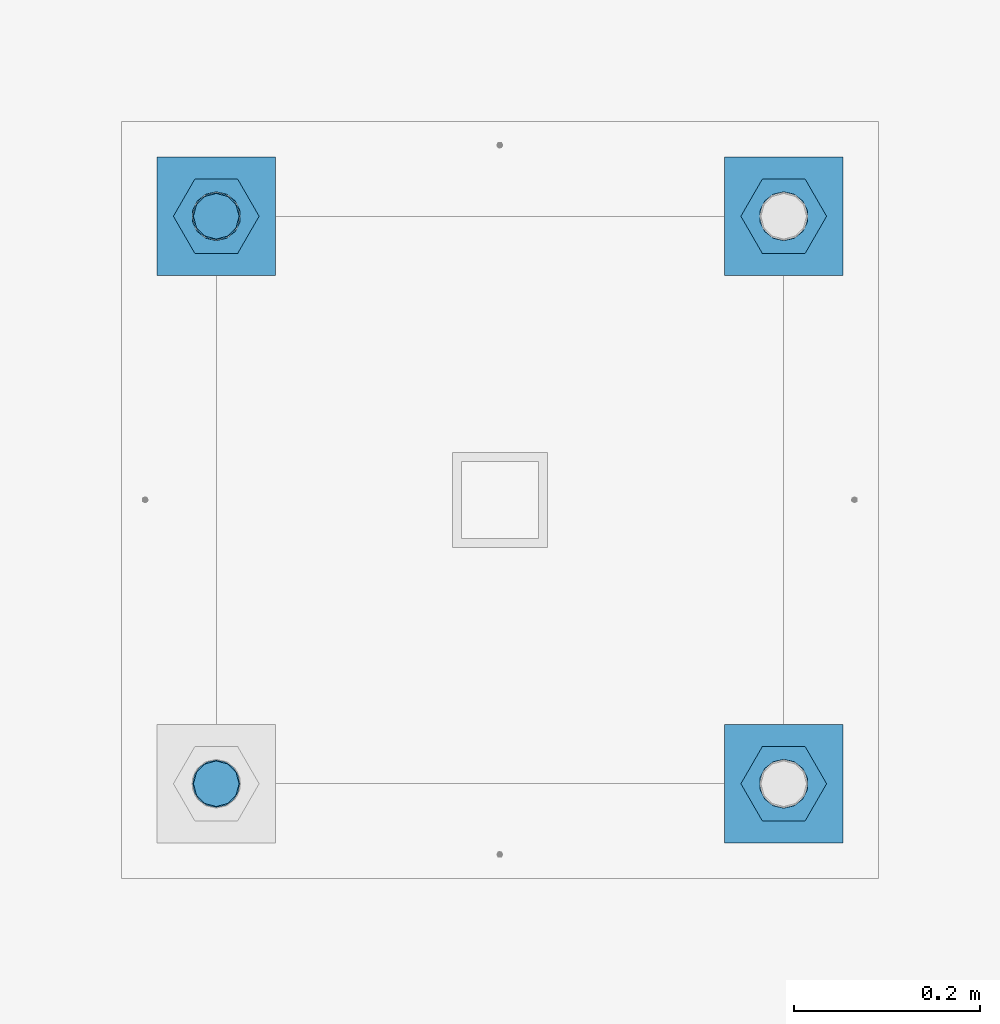
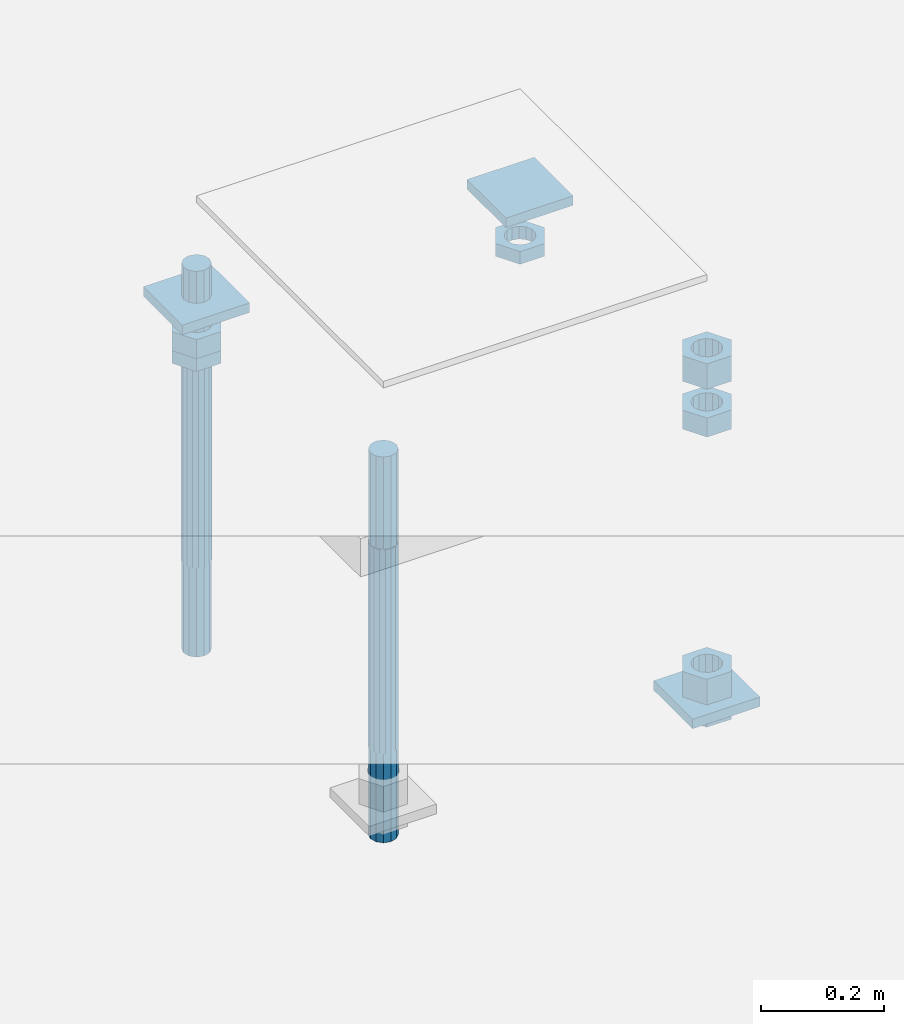
# One storey, part 2746 of 3843: 12 beams, 1 element without a shape of its own.
"""IFC2X3 building model written with IfcOpenShell, lengths in millimetres."""

from ifc_helpers import new_model, si_unit, frame, origin_with_axes, place, context, subcontext, project, spatial, faceted_brep, material, type_object, element, aggregate, save


model = new_model("IFC2X3")

# Units and contexts
model_context = context("Model", 3, precision=1e-05, world=origin_with_axes())
body_context = subcontext(model_context, "Body", "Model", "MODEL_VIEW")
ifc_project = project(units=[si_unit("LENGTHUNIT", "METRE", prefix="MILLI"), si_unit("AREAUNIT", "SQUARE_METRE"), si_unit("VOLUMEUNIT", "CUBIC_METRE"), si_unit("MASSUNIT", "GRAM", prefix="KILO"), si_unit("TIMEUNIT", "SECOND"), si_unit("PLANEANGLEUNIT", "RADIAN"), si_unit("SOLIDANGLEUNIT", "STERADIAN"), si_unit("THERMODYNAMICTEMPERATUREUNIT", "DEGREE_CELSIUS"), si_unit("LUMINOUSINTENSITYUNIT", "LUMEN")], contexts=[model_context])

# Site, building, storey
site_placement = place(None, origin_with_axes())
site = spatial("IfcSite", under=ifc_project, at=site_placement, CompositionType="ELEMENT")
building_placement = place(site_placement, origin_with_axes())
building = spatial("IfcBuilding", under=site, at=building_placement, Name="Undefined", CompositionType="ELEMENT")
storey_placement = place(building_placement, origin_with_axes())
storey = spatial("IfcBuildingStorey", under=building, at=storey_placement, Name="Undefined", CompositionType="ELEMENT", Elevation=0.0)

# Assembly, beams
assembly_placement = place(storey_placement, origin_with_axes())
assembly = element("IfcElementAssembly", 1, at=assembly_placement, inside=storey, Name="TEMPLATE", AssemblyPlace="NOTDEFINED", PredefinedType="RIGID_FRAME")
ifc_material_1 = material(Name="STEEL/A36")
beam_type_1 = type_object("IfcBeamType", PredefinedType="NOTDEFINED")
beam_1_placement = place(assembly_placement, frame((115798.6, 42113.2000015259, 29873.575), z_axis=(1.0, 0.0, 0.0), x_axis=(0.0, 1.0, 0.0)))
beam_1 = element("IfcBeam", 2, at=beam_1_placement, type_object=beam_type_1, material=ifc_material_1, Name="WASHER_PLATE", context=body_context, shape_type="Brep", body=[
    faceted_brep([(0.0, 9.52500000000146, -63.5), (0.0, 9.52500000000146, 63.5), (127.0, 9.52500000000146, 63.5), (127.0, 9.52500000000146, -63.5), (0.0, -9.52500000000146, 63.5), (127.0, -9.52500000000146, 63.5), (0.0, -9.52500000000146, -63.5), (127.0, -9.52500000000146, -63.5)], [[[0, 1, 2, 3]], [[1, 4, 5, 2]], [[4, 6, 7, 5]], [[6, 0, 3, 7]], [[5, 7, 3, 2]], [[6, 4, 1, 0]]]),
])
beam_2_placement = place(assembly_placement, frame((116408.2, 42113.2000015259, 29873.575), z_axis=(1.0, 0.0, 0.0), x_axis=(0.0, 1.0, 0.0)))
beam_2 = element("IfcBeam", 3, at=beam_2_placement, type_object=beam_type_1, material=ifc_material_1, Name="WASHER_PLATE", context=body_context, shape_type="Brep", body=[
    faceted_brep([(0.0, 9.52500000000146, -63.5), (0.0, 9.52500000000146, 63.5), (127.0, 9.52500000000146, 63.5), (127.0, 9.52500000000146, -63.5), (0.0, -9.52500000000146, 63.5), (127.0, -9.52500000000146, 63.5), (0.0, -9.52500000000146, -63.5), (127.0, -9.52500000000146, -63.5)], [[[0, 1, 2, 3]], [[1, 4, 5, 2]], [[4, 6, 7, 5]], [[6, 0, 3, 7]], [[5, 7, 3, 2]], [[6, 4, 1, 0]]]),
])
beam_3_placement = place(assembly_placement, frame((116408.2, 41503.6000015259, 29244.925), z_axis=(1.0, 0.0, 0.0), x_axis=(0.0, 1.0, 0.0)))
beam_3 = element("IfcBeam", 4, at=beam_3_placement, type_object=beam_type_1, material=ifc_material_1, Name="WASHER_PLATE", context=body_context, shape_type="Brep", body=[
    faceted_brep([(0.0, 9.52500000000146, -63.5), (0.0, 9.52500000000146, 63.5), (127.0, 9.52500000000146, 63.5), (127.0, 9.52500000000146, -63.5), (0.0, -9.52500000000146, 63.5), (127.0, -9.52500000000146, 63.5), (0.0, -9.52500000000146, -63.5), (127.0, -9.52500000000146, -63.5)], [[[0, 1, 2, 3]], [[1, 4, 5, 2]], [[4, 6, 7, 5]], [[6, 0, 3, 7]], [[5, 7, 3, 2]], [[6, 4, 1, 0]]]),
])
beam_type_2 = type_object("IfcBeamType", Name="2_HALF_NUT", PredefinedType="NOTDEFINED")
beam_4_placement = place(assembly_placement, frame((115798.6, 42176.7000015259, 29787.85), z_axis=(0.0, 1.0, 0.0), x_axis=(0.0, 0.0, -1.0)))
beam_4 = element("IfcBeam", 5, at=beam_4_placement, type_object=beam_type_2, material=ifc_material_1, Name="NUT", ObjectType="2_HALF_NUT", context=body_context, shape_type="Brep", body=[
    faceted_brep([(0.0, -46.0369987487793, 0.0), (0.0, -23.0184993743896, -39.869213104248), (25.4000000000015, -23.0184993743896, -39.869213104248), (25.4000000000015, -46.0369987487793, 0.0), (0.0, 23.0184993743896, -39.869213104248), (25.4000000000015, 23.0184993743896, -39.869213104248), (0.0, 46.0369987487793, 0.0), (25.4000000000015, 46.0369987487793, 0.0), (0.0, 23.0184993743896, 39.869213104248), (25.4000000000015, 23.0184993743896, 39.869213104248), (0.0, -23.0184993743896, 39.869213104248), (25.4000000000015, -23.0184993743896, 39.869213104248), (0.0, 0.0, 26.1940002441406), (0.0, 11.3650617044477, 23.5999013092805), (25.4000000000015, 11.3650617044477, 23.5999013092805), (25.4000000000015, 0.0, 26.1940002441406), (0.0, 20.4791109456419, 16.3316083006721), (25.4000000000015, 20.4791109456419, 16.3316083006721), (0.0, 25.5370200498292, 5.82867859874386), (25.4000000000015, 25.5370200498292, 5.82867859874386), (0.0, 25.5370200498292, -5.82867859874386), (25.4000000000015, 25.5370200498292, -5.82867859874386), (0.0, 20.4791109456419, -16.3316083006721), (25.4000000000015, 20.4791109456419, -16.3316083006721), (0.0, 11.3650617044477, -23.5999013092805), (25.4000000000015, 11.3650617044477, -23.5999013092805), (0.0, 0.0, -26.1940002441406), (25.4000000000015, 0.0, -26.1940002441406), (0.0, -11.3650617044477, -23.5999013092805), (25.4000000000015, -11.3650617044477, -23.5999013092805), (0.0, -20.4791109456419, -16.3316083006721), (25.4000000000015, -20.4791109456419, -16.3316083006721), (0.0, -25.5370200498292, -5.82867859874386), (25.4000000000015, -25.5370200498292, -5.82867859874386), (0.0, -25.5370200498292, 5.82867859874386), (25.4000000000015, -25.5370200498292, 5.82867859874386), (0.0, -20.4791109456419, 16.3316083006721), (25.4000000000015, -20.4791109456419, 16.3316083006721), (0.0, -11.3650617044477, 23.5999013092805), (25.4000000000015, -11.3650617044477, 23.5999013092805)], [[[0, 1, 2, 3]], [[1, 4, 5, 2]], [[4, 6, 7, 5]], [[6, 8, 9, 7]], [[8, 10, 11, 9]], [[10, 0, 3, 11]], [[12, 13, 14, 15]], [[13, 16, 17, 14]], [[16, 18, 19, 17]], [[18, 20, 21, 19]], [[20, 22, 23, 21]], [[22, 24, 25, 23]], [[24, 26, 27, 25]], [[26, 28, 29, 27]], [[28, 30, 31, 29]], [[30, 32, 33, 31]], [[32, 34, 35, 33]], [[34, 36, 37, 35]], [[36, 38, 39, 37]], [[38, 12, 15, 39]], [[5, 7, 9, 11, 3, 2], [17, 19, 21, 23, 25, 27, 29, 31, 33, 35, 37, 39, 15, 14]], [[10, 8, 6, 4, 1, 0], [38, 36, 34, 32, 30, 28, 26, 24, 22, 20, 18, 16, 13, 12]]]),
])
beam_5_placement = place(assembly_placement, frame((116408.2, 42176.7000015259, 29787.85), z_axis=(0.0, 1.0, 0.0), x_axis=(0.0, 0.0, -1.0)))
beam_5 = element("IfcBeam", 6, at=beam_5_placement, type_object=beam_type_2, material=ifc_material_1, Name="NUT", ObjectType="2_HALF_NUT", context=body_context, shape_type="Brep", body=[
    faceted_brep([(0.0, -46.0369987487793, 0.0), (0.0, -23.0184993743896, -39.869213104248), (25.4000000000015, -23.0184993743896, -39.869213104248), (25.4000000000015, -46.0369987487793, 0.0), (0.0, 23.0184993743896, -39.869213104248), (25.4000000000015, 23.0184993743896, -39.869213104248), (0.0, 46.0369987487793, 0.0), (25.4000000000015, 46.0369987487793, 0.0), (0.0, 23.0184993743896, 39.869213104248), (25.4000000000015, 23.0184993743896, 39.869213104248), (0.0, -23.0184993743896, 39.869213104248), (25.4000000000015, -23.0184993743896, 39.869213104248), (0.0, 0.0, 26.1940002441406), (0.0, 11.3650617044477, 23.5999013092805), (25.4000000000015, 11.3650617044477, 23.5999013092805), (25.4000000000015, 0.0, 26.1940002441406), (0.0, 20.4791109456419, 16.3316083006721), (25.4000000000015, 20.4791109456419, 16.3316083006721), (0.0, 25.5370200498292, 5.82867859874386), (25.4000000000015, 25.5370200498292, 5.82867859874386), (0.0, 25.5370200498292, -5.82867859874386), (25.4000000000015, 25.5370200498292, -5.82867859874386), (0.0, 20.4791109456419, -16.3316083006721), (25.4000000000015, 20.4791109456419, -16.3316083006721), (0.0, 11.3650617044477, -23.5999013092805), (25.4000000000015, 11.3650617044477, -23.5999013092805), (0.0, 0.0, -26.1940002441406), (25.4000000000015, 0.0, -26.1940002441406), (0.0, -11.3650617044477, -23.5999013092805), (25.4000000000015, -11.3650617044477, -23.5999013092805), (0.0, -20.4791109456419, -16.3316083006721), (25.4000000000015, -20.4791109456419, -16.3316083006721), (0.0, -25.5370200498292, -5.82867859874386), (25.4000000000015, -25.5370200498292, -5.82867859874386), (0.0, -25.5370200498292, 5.82867859874386), (25.4000000000015, -25.5370200498292, 5.82867859874386), (0.0, -20.4791109456419, 16.3316083006721), (25.4000000000015, -20.4791109456419, 16.3316083006721), (0.0, -11.3650617044477, 23.5999013092805), (25.4000000000015, -11.3650617044477, 23.5999013092805)], [[[0, 1, 2, 3]], [[1, 4, 5, 2]], [[4, 6, 7, 5]], [[6, 8, 9, 7]], [[8, 10, 11, 9]], [[10, 0, 3, 11]], [[12, 13, 14, 15]], [[13, 16, 17, 14]], [[16, 18, 19, 17]], [[18, 20, 21, 19]], [[20, 22, 23, 21]], [[22, 24, 25, 23]], [[24, 26, 27, 25]], [[26, 28, 29, 27]], [[28, 30, 31, 29]], [[30, 32, 33, 31]], [[32, 34, 35, 33]], [[34, 36, 37, 35]], [[36, 38, 39, 37]], [[38, 12, 15, 39]], [[5, 7, 9, 11, 3, 2], [17, 19, 21, 23, 25, 27, 29, 31, 33, 35, 37, 39, 15, 14]], [[10, 8, 6, 4, 1, 0], [38, 36, 34, 32, 30, 28, 26, 24, 22, 20, 18, 16, 13, 12]]]),
])
beam_6_placement = place(assembly_placement, frame((116408.2, 41567.1000015259, 29235.4), z_axis=(0.0, 1.0, 0.0), x_axis=(0.0, 0.0, -1.0)))
beam_6 = element("IfcBeam", 7, at=beam_6_placement, type_object=beam_type_2, material=ifc_material_1, Name="NUT", ObjectType="2_HALF_NUT", context=body_context, shape_type="Brep", body=[
    faceted_brep([(0.0, -46.0369987487793, 0.0), (0.0, -23.0184993743896, -39.869213104248), (25.4000000000015, -23.0184993743896, -39.869213104248), (25.4000000000015, -46.0369987487793, 0.0), (0.0, 23.0184993743896, -39.869213104248), (25.4000000000015, 23.0184993743896, -39.869213104248), (0.0, 46.0369987487793, 0.0), (25.4000000000015, 46.0369987487793, 0.0), (0.0, 23.0184993743896, 39.869213104248), (25.4000000000015, 23.0184993743896, 39.869213104248), (0.0, -23.0184993743896, 39.869213104248), (25.4000000000015, -23.0184993743896, 39.869213104248), (0.0, 0.0, 26.1940002441406), (0.0, 11.3650617044477, 23.5999013092805), (25.4000000000015, 11.3650617044477, 23.5999013092805), (25.4000000000015, 0.0, 26.1940002441406), (0.0, 20.4791109456419, 16.3316083006721), (25.4000000000015, 20.4791109456419, 16.3316083006721), (0.0, 25.5370200498292, 5.82867859874386), (25.4000000000015, 25.5370200498292, 5.82867859874386), (0.0, 25.5370200498292, -5.82867859874386), (25.4000000000015, 25.5370200498292, -5.82867859874386), (0.0, 20.4791109456419, -16.3316083006721), (25.4000000000015, 20.4791109456419, -16.3316083006721), (0.0, 11.3650617044477, -23.5999013092805), (25.4000000000015, 11.3650617044477, -23.5999013092805), (0.0, 0.0, -26.1940002441406), (25.4000000000015, 0.0, -26.1940002441406), (0.0, -11.3650617044477, -23.5999013092805), (25.4000000000015, -11.3650617044477, -23.5999013092805), (0.0, -20.4791109456419, -16.3316083006721), (25.4000000000015, -20.4791109456419, -16.3316083006721), (0.0, -25.5370200498292, -5.82867859874386), (25.4000000000015, -25.5370200498292, -5.82867859874386), (0.0, -25.5370200498292, 5.82867859874386), (25.4000000000015, -25.5370200498292, 5.82867859874386), (0.0, -20.4791109456419, 16.3316083006721), (25.4000000000015, -20.4791109456419, 16.3316083006721), (0.0, -11.3650617044477, 23.5999013092805), (25.4000000000015, -11.3650617044477, 23.5999013092805)], [[[0, 1, 2, 3]], [[1, 4, 5, 2]], [[4, 6, 7, 5]], [[6, 8, 9, 7]], [[8, 10, 11, 9]], [[10, 0, 3, 11]], [[12, 13, 14, 15]], [[13, 16, 17, 14]], [[16, 18, 19, 17]], [[18, 20, 21, 19]], [[20, 22, 23, 21]], [[22, 24, 25, 23]], [[24, 26, 27, 25]], [[26, 28, 29, 27]], [[28, 30, 31, 29]], [[30, 32, 33, 31]], [[32, 34, 35, 33]], [[34, 36, 37, 35]], [[36, 38, 39, 37]], [[38, 12, 15, 39]], [[5, 7, 9, 11, 3, 2], [17, 19, 21, 23, 25, 27, 29, 31, 33, 35, 37, 39, 15, 14]], [[10, 8, 6, 4, 1, 0], [38, 36, 34, 32, 30, 28, 26, 24, 22, 20, 18, 16, 13, 12]]]),
])
beam_type_3 = type_object("IfcBeamType", Name="2_HEAVY_HEX_NUT", PredefinedType="NOTDEFINED")
beam_7_placement = place(assembly_placement, frame((116408.2, 41567.1000015259, 29825.95), z_axis=(0.0, 1.0, 0.0), x_axis=(0.0, 0.0, -1.0)))
beam_7 = element("IfcBeam", 8, at=beam_7_placement, type_object=beam_type_3, material=ifc_material_1, Name="NUT", ObjectType="2_HEAVY_HEX_NUT", context=body_context, shape_type="Brep", body=[
    faceted_brep([(0.0, -46.0369987487793, 0.0), (0.0, -23.0184993743896, -39.869213104248), (38.0999999999985, -23.0184993743896, -39.869213104248), (38.0999999999985, -46.0369987487793, 0.0), (0.0, 23.0184993743896, -39.869213104248), (38.0999999999985, 23.0184993743896, -39.869213104248), (0.0, 46.0369987487793, 0.0), (38.0999999999985, 46.0369987487793, 0.0), (0.0, 23.0184993743896, 39.869213104248), (38.0999999999985, 23.0184993743896, 39.869213104248), (0.0, -23.0184993743896, 39.869213104248), (38.0999999999985, -23.0184993743896, 39.869213104248), (0.0, 0.0, 26.1940002441406), (0.0, 11.3650617044477, 23.5999013092805), (38.0999999999985, 11.3650617044477, 23.5999013092805), (38.0999999999985, 0.0, 26.1940002441406), (0.0, 20.4791109456419, 16.3316083006721), (38.0999999999985, 20.4791109456419, 16.3316083006721), (0.0, 25.5370200498292, 5.82867859874386), (38.0999999999985, 25.5370200498292, 5.82867859874386), (0.0, 25.5370200498292, -5.82867859874386), (38.0999999999985, 25.5370200498292, -5.82867859874386), (0.0, 20.4791109456419, -16.3316083006721), (38.0999999999985, 20.4791109456419, -16.3316083006721), (0.0, 11.3650617044477, -23.5999013092805), (38.0999999999985, 11.3650617044477, -23.5999013092805), (0.0, 0.0, -26.1940002441406), (38.0999999999985, 0.0, -26.1940002441406), (0.0, -11.3650617044477, -23.5999013092805), (38.0999999999985, -11.3650617044477, -23.5999013092805), (0.0, -20.4791109456419, -16.3316083006721), (38.0999999999985, -20.4791109456419, -16.3316083006721), (0.0, -25.5370200498292, -5.82867859874386), (38.0999999999985, -25.5370200498292, -5.82867859874386), (0.0, -25.5370200498292, 5.82867859874386), (38.0999999999985, -25.5370200498292, 5.82867859874386), (0.0, -20.4791109456419, 16.3316083006721), (38.0999999999985, -20.4791109456419, 16.3316083006721), (0.0, -11.3650617044477, 23.5999013092805), (38.0999999999985, -11.3650617044477, 23.5999013092805)], [[[0, 1, 2, 3]], [[1, 4, 5, 2]], [[4, 6, 7, 5]], [[6, 8, 9, 7]], [[8, 10, 11, 9]], [[10, 0, 3, 11]], [[12, 13, 14, 15]], [[13, 16, 17, 14]], [[16, 18, 19, 17]], [[18, 20, 21, 19]], [[20, 22, 23, 21]], [[22, 24, 25, 23]], [[24, 26, 27, 25]], [[26, 28, 29, 27]], [[28, 30, 31, 29]], [[30, 32, 33, 31]], [[32, 34, 35, 33]], [[34, 36, 37, 35]], [[36, 38, 39, 37]], [[38, 12, 15, 39]], [[5, 7, 9, 11, 3, 2], [17, 19, 21, 23, 25, 27, 29, 31, 33, 35, 37, 39, 15, 14]], [[10, 8, 6, 4, 1, 0], [38, 36, 34, 32, 30, 28, 26, 24, 22, 20, 18, 16, 13, 12]]]),
])
beam_8_placement = place(assembly_placement, frame((116408.2, 41567.1000015259, 29933.9), z_axis=(0.0, 1.0, 0.0), x_axis=(0.0, 0.0, -1.0)))
beam_8 = element("IfcBeam", 9, at=beam_8_placement, type_object=beam_type_3, material=ifc_material_1, Name="NUT", ObjectType="2_HEAVY_HEX_NUT", context=body_context, shape_type="Brep", body=[
    faceted_brep([(0.0, -46.0369987487793, 0.0), (0.0, -23.0184993743896, -39.869213104248), (50.7999999999993, -23.0184993743896, -39.869213104248), (50.7999999999993, -46.0369987487793, 0.0), (0.0, 23.0184993743896, -39.869213104248), (50.7999999999993, 23.0184993743896, -39.869213104248), (0.0, 46.0369987487793, 0.0), (50.7999999999993, 46.0369987487793, 0.0), (0.0, 23.0184993743896, 39.869213104248), (50.7999999999993, 23.0184993743896, 39.869213104248), (0.0, -23.0184993743896, 39.869213104248), (50.7999999999993, -23.0184993743896, 39.869213104248), (0.0, 0.0, 26.1940002441406), (0.0, 11.3650617044477, 23.5999013092805), (50.7999999999993, 11.3650617044477, 23.5999013092805), (50.7999999999993, 0.0, 26.1940002441406), (0.0, 20.4791109456419, 16.3316083006721), (50.7999999999993, 20.4791109456419, 16.3316083006721), (0.0, 25.5370200498292, 5.82867859874386), (50.7999999999993, 25.5370200498292, 5.82867859874386), (0.0, 25.5370200498292, -5.82867859874386), (50.7999999999993, 25.5370200498292, -5.82867859874386), (0.0, 20.4791109456419, -16.3316083006721), (50.7999999999993, 20.4791109456419, -16.3316083006721), (0.0, 11.3650617044477, -23.5999013092805), (50.7999999999993, 11.3650617044477, -23.5999013092805), (0.0, 0.0, -26.1940002441406), (50.7999999999993, 0.0, -26.1940002441406), (0.0, -11.3650617044477, -23.5999013092805), (50.7999999999993, -11.3650617044477, -23.5999013092805), (0.0, -20.4791109456419, -16.3316083006721), (50.7999999999993, -20.4791109456419, -16.3316083006721), (0.0, -25.5370200498292, -5.82867859874386), (50.7999999999993, -25.5370200498292, -5.82867859874386), (0.0, -25.5370200498292, 5.82867859874386), (50.7999999999993, -25.5370200498292, 5.82867859874386), (0.0, -20.4791109456419, 16.3316083006721), (50.7999999999993, -20.4791109456419, 16.3316083006721), (0.0, -11.3650617044477, 23.5999013092805), (50.7999999999993, -11.3650617044477, 23.5999013092805)], [[[0, 1, 2, 3]], [[1, 4, 5, 2]], [[4, 6, 7, 5]], [[6, 8, 9, 7]], [[8, 10, 11, 9]], [[10, 0, 3, 11]], [[12, 13, 14, 15]], [[13, 16, 17, 14]], [[16, 18, 19, 17]], [[18, 20, 21, 19]], [[20, 22, 23, 21]], [[22, 24, 25, 23]], [[24, 26, 27, 25]], [[26, 28, 29, 27]], [[28, 30, 31, 29]], [[30, 32, 33, 31]], [[32, 34, 35, 33]], [[34, 36, 37, 35]], [[36, 38, 39, 37]], [[38, 12, 15, 39]], [[5, 7, 9, 11, 3, 2], [17, 19, 21, 23, 25, 27, 29, 31, 33, 35, 37, 39, 15, 14]], [[10, 8, 6, 4, 1, 0], [38, 36, 34, 32, 30, 28, 26, 24, 22, 20, 18, 16, 13, 12]]]),
])
beam_9_placement = place(assembly_placement, frame((116408.2, 41567.1000015259, 29305.25), z_axis=(0.0, 1.0, 0.0), x_axis=(0.0, 0.0, -1.0)))
beam_9 = element("IfcBeam", 10, at=beam_9_placement, type_object=beam_type_3, material=ifc_material_1, Name="NUT", ObjectType="2_HEAVY_HEX_NUT", context=body_context, shape_type="Brep", body=[
    faceted_brep([(0.0, -46.0369987487793, 0.0), (0.0, -23.0184993743896, -39.869213104248), (50.7999999999993, -23.0184993743896, -39.869213104248), (50.7999999999993, -46.0369987487793, 0.0), (0.0, 23.0184993743896, -39.869213104248), (50.7999999999993, 23.0184993743896, -39.869213104248), (0.0, 46.0369987487793, 0.0), (50.7999999999993, 46.0369987487793, 0.0), (0.0, 23.0184993743896, 39.869213104248), (50.7999999999993, 23.0184993743896, 39.869213104248), (0.0, -23.0184993743896, 39.869213104248), (50.7999999999993, -23.0184993743896, 39.869213104248), (0.0, 0.0, 26.1940002441406), (0.0, 11.3650617044477, 23.5999013092805), (50.7999999999993, 11.3650617044477, 23.5999013092805), (50.7999999999993, 0.0, 26.1940002441406), (0.0, 20.4791109456419, 16.3316083006721), (50.7999999999993, 20.4791109456419, 16.3316083006721), (0.0, 25.5370200498292, 5.82867859874386), (50.7999999999993, 25.5370200498292, 5.82867859874386), (0.0, 25.5370200498292, -5.82867859874386), (50.7999999999993, 25.5370200498292, -5.82867859874386), (0.0, 20.4791109456419, -16.3316083006721), (50.7999999999993, 20.4791109456419, -16.3316083006721), (0.0, 11.3650617044477, -23.5999013092805), (50.7999999999993, 11.3650617044477, -23.5999013092805), (0.0, 0.0, -26.1940002441406), (50.7999999999993, 0.0, -26.1940002441406), (0.0, -11.3650617044477, -23.5999013092805), (50.7999999999993, -11.3650617044477, -23.5999013092805), (0.0, -20.4791109456419, -16.3316083006721), (50.7999999999993, -20.4791109456419, -16.3316083006721), (0.0, -25.5370200498292, -5.82867859874386), (50.7999999999993, -25.5370200498292, -5.82867859874386), (0.0, -25.5370200498292, 5.82867859874386), (50.7999999999993, -25.5370200498292, 5.82867859874386), (0.0, -20.4791109456419, 16.3316083006721), (50.7999999999993, -20.4791109456419, 16.3316083006721), (0.0, -11.3650617044477, 23.5999013092805), (50.7999999999993, -11.3650617044477, 23.5999013092805)], [[[0, 1, 2, 3]], [[1, 4, 5, 2]], [[4, 6, 7, 5]], [[6, 8, 9, 7]], [[8, 10, 11, 9]], [[10, 0, 3, 11]], [[12, 13, 14, 15]], [[13, 16, 17, 14]], [[16, 18, 19, 17]], [[18, 20, 21, 19]], [[20, 22, 23, 21]], [[22, 24, 25, 23]], [[24, 26, 27, 25]], [[26, 28, 29, 27]], [[28, 30, 31, 29]], [[30, 32, 33, 31]], [[32, 34, 35, 33]], [[34, 36, 37, 35]], [[36, 38, 39, 37]], [[38, 12, 15, 39]], [[5, 7, 9, 11, 3, 2], [17, 19, 21, 23, 25, 27, 29, 31, 33, 35, 37, 39, 15, 14]], [[10, 8, 6, 4, 1, 0], [38, 36, 34, 32, 30, 28, 26, 24, 22, 20, 18, 16, 13, 12]]]),
])
beam_10_placement = place(assembly_placement, frame((115798.6, 42176.7000015259, 29825.95), z_axis=(0.0, 1.0, 0.0), x_axis=(0.0, 0.0, -1.0)))
beam_10 = element("IfcBeam", 11, at=beam_10_placement, type_object=beam_type_3, material=ifc_material_1, Name="NUT", ObjectType="2_HEAVY_HEX_NUT", context=body_context, shape_type="Brep", body=[
    faceted_brep([(0.0, -46.0369987487793, 0.0), (0.0, -23.0184993743896, -39.869213104248), (38.0999999999985, -23.0184993743896, -39.869213104248), (38.0999999999985, -46.0369987487793, 0.0), (0.0, 23.0184993743896, -39.869213104248), (38.0999999999985, 23.0184993743896, -39.869213104248), (0.0, 46.0369987487793, 0.0), (38.0999999999985, 46.0369987487793, 0.0), (0.0, 23.0184993743896, 39.869213104248), (38.0999999999985, 23.0184993743896, 39.869213104248), (0.0, -23.0184993743896, 39.869213104248), (38.0999999999985, -23.0184993743896, 39.869213104248), (0.0, 0.0, 26.1940002441406), (0.0, 11.3650617044477, 23.5999013092805), (38.0999999999985, 11.3650617044477, 23.5999013092805), (38.0999999999985, 0.0, 26.1940002441406), (0.0, 20.4791109456419, 16.3316083006721), (38.0999999999985, 20.4791109456419, 16.3316083006721), (0.0, 25.5370200498292, 5.82867859874386), (38.0999999999985, 25.5370200498292, 5.82867859874386), (0.0, 25.5370200498292, -5.82867859874386), (38.0999999999985, 25.5370200498292, -5.82867859874386), (0.0, 20.4791109456419, -16.3316083006721), (38.0999999999985, 20.4791109456419, -16.3316083006721), (0.0, 11.3650617044477, -23.5999013092805), (38.0999999999985, 11.3650617044477, -23.5999013092805), (0.0, 0.0, -26.1940002441406), (38.0999999999985, 0.0, -26.1940002441406), (0.0, -11.3650617044477, -23.5999013092805), (38.0999999999985, -11.3650617044477, -23.5999013092805), (0.0, -20.4791109456419, -16.3316083006721), (38.0999999999985, -20.4791109456419, -16.3316083006721), (0.0, -25.5370200498292, -5.82867859874386), (38.0999999999985, -25.5370200498292, -5.82867859874386), (0.0, -25.5370200498292, 5.82867859874386), (38.0999999999985, -25.5370200498292, 5.82867859874386), (0.0, -20.4791109456419, 16.3316083006721), (38.0999999999985, -20.4791109456419, 16.3316083006721), (0.0, -11.3650617044477, 23.5999013092805), (38.0999999999985, -11.3650617044477, 23.5999013092805)], [[[0, 1, 2, 3]], [[1, 4, 5, 2]], [[4, 6, 7, 5]], [[6, 8, 9, 7]], [[8, 10, 11, 9]], [[10, 0, 3, 11]], [[12, 13, 14, 15]], [[13, 16, 17, 14]], [[16, 18, 19, 17]], [[18, 20, 21, 19]], [[20, 22, 23, 21]], [[22, 24, 25, 23]], [[24, 26, 27, 25]], [[26, 28, 29, 27]], [[28, 30, 31, 29]], [[30, 32, 33, 31]], [[32, 34, 35, 33]], [[34, 36, 37, 35]], [[36, 38, 39, 37]], [[38, 12, 15, 39]], [[5, 7, 9, 11, 3, 2], [17, 19, 21, 23, 25, 27, 29, 31, 33, 35, 37, 39, 15, 14]], [[10, 8, 6, 4, 1, 0], [38, 36, 34, 32, 30, 28, 26, 24, 22, 20, 18, 16, 13, 12]]]),
])
ifc_material_2 = material()
beam_type_4 = type_object("IfcBeamType", PredefinedType="NOTDEFINED")
beam_11_placement = place(assembly_placement, frame((115798.6, 42176.7000015259, 29762.45), z_axis=(0.0, 1.0, 0.0), x_axis=(0.0, 0.0, -1.0)))
beam_11 = element("IfcBeam", 12, at=beam_11_placement, type_object=beam_type_4, material=ifc_material_2, Name="ANCHOR_ROD", context=body_context, shape_type="Brep", body=[
    faceted_brep([(-184.150000000001, -21.217622392709, 12.25), (-184.150000000001, -12.2499999999854, 21.2176223927163), (-184.150000000001, 1.45519152283669e-11, 24.5), (-184.150000000001, 12.2500000000146, 21.2176223927163), (-184.150000000001, 21.2176223927381, 12.25), (-184.150000000001, 24.5000000000146, 0.0), (-184.150000000001, 21.2176223927381, -12.25), (-184.150000000001, 12.2500000000146, -21.2176223927163), (-184.150000000001, 1.45519152283669e-11, -24.5), (-184.150000000001, -12.2499999999854, -21.2176223927163), (-184.150000000001, -21.217622392709, -12.25), (-184.150000000001, -24.4999999999854, 0.0), (0.0, 24.5000000000146, 0.0), (0.0, 21.2176223927381, -12.25), (0.0, 12.2500000000146, -21.2176223927163), (0.0, 1.45519152283669e-11, -24.5), (0.0, -12.2499999999854, -21.2176223927163), (0.0, -21.217622392709, -12.25), (0.0, -24.4999999999854, 0.0), (0.0, -21.217622392709, 12.25), (0.0, -12.2499999999854, 21.2176223927163), (0.0, 1.45519152283669e-11, 24.5), (0.0, 12.2500000000146, 21.2176223927163), (0.0, 21.2176223927381, 12.25), (0.0, -23.4665401257807, 9.72015918207035), (0.0, -17.9605122421344, 17.9605122421417), (0.0, -9.72015918207762, 23.466540125788), (0.0, 0.0, 25.4000000000015), (0.0, 9.72015918207762, 23.466540125788), (0.0, 17.9605122421344, 17.9605122421417), (0.0, 23.4665401257807, 9.72015918207035), (0.0, 25.3999996185303, 0.0), (0.0, 23.4665401257807, -9.72015918207035), (0.0, 17.9605122421344, -17.9605122421417), (0.0, 9.72015918207762, -23.466540125788), (0.0, 0.0, -25.4000000000015), (0.0, -9.72015918207762, -23.466540125788), (0.0, -17.9605122421344, -17.9605122421417), (0.0, -23.4665401257807, -9.72015918207035), (0.0, -25.3999996185303, 0.0), (406.399999999998, -25.3999999999942, 0.0), (406.399999999998, -23.4665401257807, 9.72015918207035), (406.399999999998, -17.9605122421344, 17.9605122421417), (406.399999999998, -9.72015918207762, 23.466540125788), (406.399999999998, 0.0, 25.4000000000015), (406.399999999998, 9.72015918207762, 23.466540125788), (406.399999999998, 17.9605122421344, 17.9605122421417), (406.399999999998, 23.4665401257807, 9.72015918207035), (406.399999999998, 25.3999999999942, 0.0), (406.399999999998, 23.4665401257807, -9.72015918207035), (406.399999999998, 17.9605122421344, -17.9605122421417), (406.399999999998, 9.72015918207762, -23.466540125788), (406.399999999998, 0.0, -25.4000000000015), (406.399999999998, -9.72015918207762, -23.466540125788), (406.399999999998, -17.9605122421344, -17.9605122421417), (406.399999999998, -23.4665401257807, -9.72015918207035), (406.399999999998, -12.2499999999854, 21.2176223927163), (406.399999999998, 1.45519152283669e-11, 24.5), (406.399999999998, 12.2500000000146, 21.2176223927163), (406.399999999998, 21.2176223927381, 12.25), (406.399999999998, 24.5000000000146, 0.0), (406.399999999998, 21.2176223927381, -12.25), (406.399999999998, 12.2500000000146, -21.2176223927163), (406.399999999998, 1.45519152283669e-11, -24.5), (406.399999999998, -12.2499999999854, -21.2176223927163), (406.399999999998, -21.217622392709, -12.25), (406.399999999998, -24.4999999999854, 0.0), (406.399999999998, -21.217622392709, 12.25), (584.200000000001, -12.2499999999854, -21.2176223927163), (584.200000000001, 1.45519152283669e-11, -24.5), (584.200000000001, 12.2500000000146, -21.2176223927163), (584.200000000001, 21.2176223927381, -12.25), (584.200000000001, 24.5000000000146, 0.0), (584.200000000001, 21.2176223927381, 12.25), (584.200000000001, 12.2500000000146, 21.2176223927163), (584.200000000001, 1.45519152283669e-11, 24.5), (584.200000000001, -12.2499999999854, 21.2176223927163), (584.200000000001, -21.217622392709, 12.25), (584.200000000001, -24.4999999999854, 0.0), (584.200000000001, -21.217622392709, -12.25)], [[[0, 1, 2, 3, 4, 5, 6, 7, 8, 9, 10, 11]], [[6, 5, 12, 13]], [[7, 6, 13, 14]], [[8, 7, 14, 15]], [[9, 8, 15, 16]], [[10, 9, 16, 17]], [[11, 10, 17, 18]], [[0, 11, 18, 19]], [[1, 0, 19, 20]], [[2, 1, 20, 21]], [[3, 2, 21, 22]], [[4, 3, 22, 23]], [[5, 4, 23, 12]], [[24, 25, 26, 27, 28, 29, 30, 31, 32, 33, 34, 35, 36, 37, 38, 39], [22, 21, 20, 19, 18, 17, 16, 15, 14, 13, 12, 23]], [[24, 39, 40, 41]], [[25, 24, 41, 42]], [[26, 25, 42, 43]], [[27, 26, 43, 44]], [[28, 27, 44, 45]], [[29, 28, 45, 46]], [[30, 29, 46, 47]], [[31, 30, 47, 48]], [[32, 31, 48, 49]], [[33, 32, 49, 50]], [[34, 33, 50, 51]], [[35, 34, 51, 52]], [[36, 35, 52, 53]], [[37, 36, 53, 54]], [[38, 37, 54, 55]], [[39, 38, 55, 40]], [[54, 53, 52, 51, 50, 49, 48, 47, 46, 45, 44, 43, 42, 41, 40, 55], [56, 57, 58, 59, 60, 61, 62, 63, 64, 65, 66, 67]], [[68, 69, 70, 71, 72, 73, 74, 75, 76, 77, 78, 79]], [[76, 75, 57, 56]], [[77, 76, 56, 67]], [[78, 77, 67, 66]], [[79, 78, 66, 65]], [[68, 79, 65, 64]], [[69, 68, 64, 63]], [[70, 69, 63, 62]], [[71, 70, 62, 61]], [[72, 71, 61, 60]], [[73, 72, 60, 59]], [[74, 73, 59, 58]], [[75, 74, 58, 57]]]),
])
beam_12_placement = place(assembly_placement, frame((115798.6, 41567.1000015259, 29762.45), z_axis=(0.0, 1.0, 0.0), x_axis=(0.0, 0.0, -1.0)))
beam_12 = element("IfcBeam", 13, at=beam_12_placement, type_object=beam_type_4, material=ifc_material_2, Name="ANCHOR_ROD", context=body_context, shape_type="Brep", body=[
    faceted_brep([(-184.150000000001, -21.217622392709, 12.25), (-184.150000000001, -12.2499999999854, 21.2176223927163), (-184.150000000001, 1.45519152283669e-11, 24.5), (-184.150000000001, 12.2500000000146, 21.2176223927163), (-184.150000000001, 21.2176223927381, 12.25), (-184.150000000001, 24.5000000000146, 0.0), (-184.150000000001, 21.2176223927381, -12.25), (-184.150000000001, 12.2500000000146, -21.2176223927163), (-184.150000000001, 1.45519152283669e-11, -24.5), (-184.150000000001, -12.2499999999854, -21.2176223927163), (-184.150000000001, -21.217622392709, -12.25), (-184.150000000001, -24.4999999999854, 0.0), (0.0, 24.5000000000146, 0.0), (0.0, 21.2176223927381, -12.25), (0.0, 12.2500000000146, -21.2176223927163), (0.0, 1.45519152283669e-11, -24.5), (0.0, -12.2499999999854, -21.2176223927163), (0.0, -21.217622392709, -12.25), (0.0, -24.4999999999854, 0.0), (0.0, -21.217622392709, 12.25), (0.0, -12.2499999999854, 21.2176223927163), (0.0, 1.45519152283669e-11, 24.5), (0.0, 12.2500000000146, 21.2176223927163), (0.0, 21.2176223927381, 12.25), (0.0, -23.4665401257807, 9.72015918207035), (0.0, -17.9605122421344, 17.9605122421417), (0.0, -9.72015918207762, 23.466540125788), (0.0, 0.0, 25.4000000000015), (0.0, 9.72015918207762, 23.466540125788), (0.0, 17.9605122421344, 17.9605122421417), (0.0, 23.4665401257807, 9.72015918207035), (0.0, 25.3999996185303, 0.0), (0.0, 23.4665401257807, -9.72015918207035), (0.0, 17.9605122421344, -17.9605122421417), (0.0, 9.72015918207762, -23.466540125788), (0.0, 0.0, -25.4000000000015), (0.0, -9.72015918207762, -23.466540125788), (0.0, -17.9605122421344, -17.9605122421417), (0.0, -23.4665401257807, -9.72015918207035), (0.0, -25.3999996185303, 0.0), (406.399999999998, -25.3999999999942, 0.0), (406.399999999998, -23.4665401257807, 9.72015918207035), (406.399999999998, -17.9605122421344, 17.9605122421417), (406.399999999998, -9.72015918207762, 23.466540125788), (406.399999999998, 0.0, 25.4000000000015), (406.399999999998, 9.72015918207762, 23.466540125788), (406.399999999998, 17.9605122421344, 17.9605122421417), (406.399999999998, 23.4665401257807, 9.72015918207035), (406.399999999998, 25.3999999999942, 0.0), (406.399999999998, 23.4665401257807, -9.72015918207035), (406.399999999998, 17.9605122421344, -17.9605122421417), (406.399999999998, 9.72015918207762, -23.466540125788), (406.399999999998, 0.0, -25.4000000000015), (406.399999999998, -9.72015918207762, -23.466540125788), (406.399999999998, -17.9605122421344, -17.9605122421417), (406.399999999998, -23.4665401257807, -9.72015918207035), (406.399999999998, -12.2499999999854, 21.2176223927163), (406.399999999998, 1.45519152283669e-11, 24.5), (406.399999999998, 12.2500000000146, 21.2176223927163), (406.399999999998, 21.2176223927381, 12.25), (406.399999999998, 24.5000000000146, 0.0), (406.399999999998, 21.2176223927381, -12.25), (406.399999999998, 12.2500000000146, -21.2176223927163), (406.399999999998, 1.45519152283669e-11, -24.5), (406.399999999998, -12.2499999999854, -21.2176223927163), (406.399999999998, -21.217622392709, -12.25), (406.399999999998, -24.4999999999854, 0.0), (406.399999999998, -21.217622392709, 12.25), (584.200000000001, -12.2499999999854, -21.2176223927163), (584.200000000001, 1.45519152283669e-11, -24.5), (584.200000000001, 12.2500000000146, -21.2176223927163), (584.200000000001, 21.2176223927381, -12.25), (584.200000000001, 24.5000000000146, 0.0), (584.200000000001, 21.2176223927381, 12.25), (584.200000000001, 12.2500000000146, 21.2176223927163), (584.200000000001, 1.45519152283669e-11, 24.5), (584.200000000001, -12.2499999999854, 21.2176223927163), (584.200000000001, -21.217622392709, 12.25), (584.200000000001, -24.4999999999854, 0.0), (584.200000000001, -21.217622392709, -12.25)], [[[0, 1, 2, 3, 4, 5, 6, 7, 8, 9, 10, 11]], [[6, 5, 12, 13]], [[7, 6, 13, 14]], [[8, 7, 14, 15]], [[9, 8, 15, 16]], [[10, 9, 16, 17]], [[11, 10, 17, 18]], [[0, 11, 18, 19]], [[1, 0, 19, 20]], [[2, 1, 20, 21]], [[3, 2, 21, 22]], [[4, 3, 22, 23]], [[5, 4, 23, 12]], [[24, 25, 26, 27, 28, 29, 30, 31, 32, 33, 34, 35, 36, 37, 38, 39], [22, 21, 20, 19, 18, 17, 16, 15, 14, 13, 12, 23]], [[24, 39, 40, 41]], [[25, 24, 41, 42]], [[26, 25, 42, 43]], [[27, 26, 43, 44]], [[28, 27, 44, 45]], [[29, 28, 45, 46]], [[30, 29, 46, 47]], [[31, 30, 47, 48]], [[32, 31, 48, 49]], [[33, 32, 49, 50]], [[34, 33, 50, 51]], [[35, 34, 51, 52]], [[36, 35, 52, 53]], [[37, 36, 53, 54]], [[38, 37, 54, 55]], [[39, 38, 55, 40]], [[54, 53, 52, 51, 50, 49, 48, 47, 46, 45, 44, 43, 42, 41, 40, 55], [56, 57, 58, 59, 60, 61, 62, 63, 64, 65, 66, 67]], [[68, 69, 70, 71, 72, 73, 74, 75, 76, 77, 78, 79]], [[76, 75, 57, 56]], [[77, 76, 56, 67]], [[78, 77, 67, 66]], [[79, 78, 66, 65]], [[68, 79, 65, 64]], [[69, 68, 64, 63]], [[70, 69, 63, 62]], [[71, 70, 62, 61]], [[72, 71, 61, 60]], [[73, 72, 60, 59]], [[74, 73, 59, 58]], [[75, 74, 58, 57]]]),
])
aggregate(assembly, [beam_4, beam_5, beam_1, beam_2, beam_7, beam_8, beam_9, beam_6, beam_3, beam_11, beam_10, beam_12])

save(model, "model.ifc")
